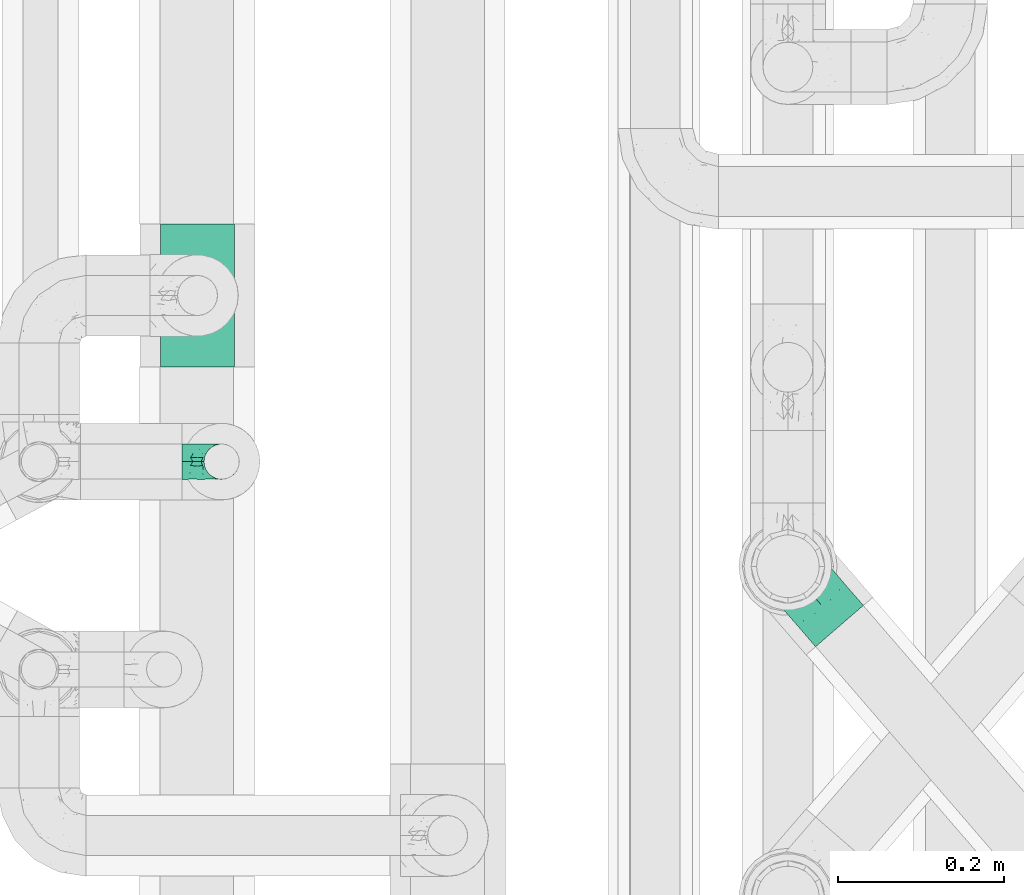
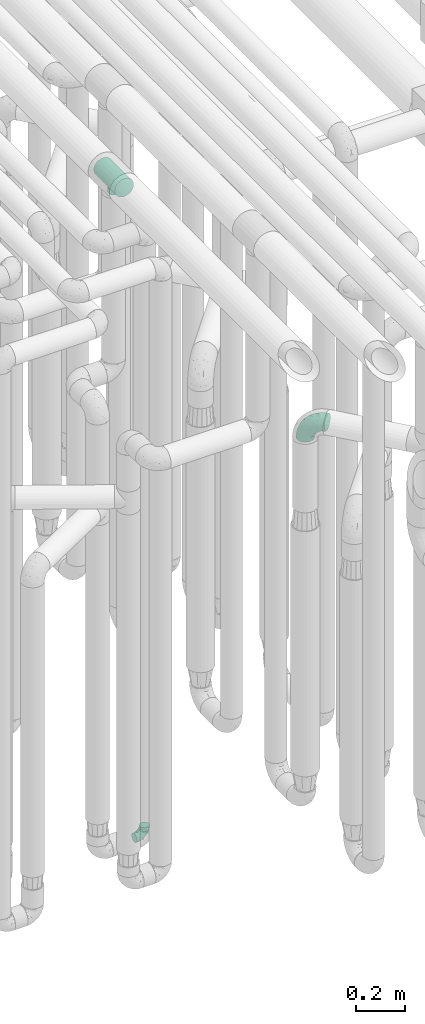
# One storey, part 611 of 827: 3 flow fittings.
"""IFC2X3 building model written with IfcOpenShell, lengths in millimetres."""

from ifc_helpers import new_model, entity, si_unit, converted_unit, derived_unit, direction, frame, origin, place, context, subcontext, project, spatial, faceted_brep, source, transform, mapped, material, type_object, type_shapes, element, save


model = new_model("IFC2X3")

# Units and contexts
model_context = context("Model", 3, precision=0.01, world=origin(), true_north=direction((6.12303176911189e-17, 1.0)))
body_context = subcontext(model_context, "Body", "Model", "MODEL_VIEW")
ifc_project = project(units=[si_unit("LENGTHUNIT", "METRE", prefix="MILLI"), si_unit("AREAUNIT", "SQUARE_METRE"), si_unit("VOLUMEUNIT", "CUBIC_METRE"), converted_unit("PLANEANGLEUNIT", "DEGREE", entity("IfcRatioMeasure", 0.0174532925199433), si_unit("PLANEANGLEUNIT", "RADIAN"), dimensions=[0, 0, 0, 0, 0, 0, 0]), si_unit("MASSUNIT", "GRAM", prefix="KILO"), derived_unit("MASSDENSITYUNIT", [(si_unit("MASSUNIT", "GRAM", prefix="KILO"), 1), (si_unit("LENGTHUNIT", "METRE"), -3)]), derived_unit("MOMENTOFINERTIAUNIT", [(si_unit("LENGTHUNIT", "METRE"), 4)]), si_unit("TIMEUNIT", "SECOND"), si_unit("FREQUENCYUNIT", "HERTZ"), si_unit("THERMODYNAMICTEMPERATUREUNIT", "DEGREE_CELSIUS"), derived_unit("THERMALTRANSMITTANCEUNIT", [(si_unit("MASSUNIT", "GRAM", prefix="KILO"), 1), (si_unit("THERMODYNAMICTEMPERATUREUNIT", "KELVIN"), -1), (si_unit("TIMEUNIT", "SECOND"), -3)]), derived_unit("VOLUMETRICFLOWRATEUNIT", [(si_unit("LENGTHUNIT", "METRE"), 3), (si_unit("TIMEUNIT", "SECOND"), -1)]), derived_unit("MASSFLOWRATEUNIT", [(si_unit("MASSUNIT", "GRAM", prefix="KILO"), 1), (si_unit("TIMEUNIT", "SECOND"), -1)]), derived_unit("ROTATIONALFREQUENCYUNIT", [(si_unit("TIMEUNIT", "SECOND"), -1)]), si_unit("ELECTRICCURRENTUNIT", "AMPERE"), si_unit("ELECTRICVOLTAGEUNIT", "VOLT"), si_unit("POWERUNIT", "WATT"), si_unit("FORCEUNIT", "NEWTON", prefix="KILO"), si_unit("ILLUMINANCEUNIT", "LUX"), si_unit("LUMINOUSFLUXUNIT", "LUMEN"), si_unit("LUMINOUSINTENSITYUNIT", "CANDELA"), derived_unit("USERDEFINED", [(si_unit("MASSUNIT", "GRAM", prefix="KILO"), -1), (si_unit("LENGTHUNIT", "METRE"), -2), (si_unit("TIMEUNIT", "SECOND"), 3), (si_unit("LUMINOUSFLUXUNIT", "LUMEN"), 1)]), derived_unit("LINEARVELOCITYUNIT", [(si_unit("LENGTHUNIT", "METRE"), 1), (si_unit("TIMEUNIT", "SECOND"), -1)]), si_unit("PRESSUREUNIT", "PASCAL"), derived_unit("USERDEFINED", [(si_unit("LENGTHUNIT", "METRE"), -2), (si_unit("MASSUNIT", "GRAM", prefix="KILO"), 1), (si_unit("TIMEUNIT", "SECOND"), -2)]), derived_unit("LINEARFORCEUNIT", [(si_unit("MASSUNIT", "GRAM", prefix="KILO"), 1), (si_unit("LENGTHUNIT", "METRE"), 1), (si_unit("TIMEUNIT", "SECOND"), -2), (si_unit("LENGTHUNIT", "METRE"), -1)]), derived_unit("PLANARFORCEUNIT", [(si_unit("MASSUNIT", "GRAM", prefix="KILO"), 1), (si_unit("LENGTHUNIT", "METRE"), 1), (si_unit("TIMEUNIT", "SECOND"), -2), (si_unit("LENGTHUNIT", "METRE"), -2)])], contexts=[model_context])

# Site, building, storey
site_placement = place(None, origin())
site = spatial("IfcSite", under=ifc_project, at=site_placement, CompositionType="ELEMENT")
building_placement = place(site_placement, origin())
building = spatial("IfcBuilding", under=site, at=building_placement, CompositionType="ELEMENT")
storey_placement = place(building_placement, frame((0.0, 0.0, 28200.0)))
storey = spatial("IfcBuildingStorey", under=building, at=storey_placement, Name="08", CompositionType="ELEMENT", Elevation=28200.0)

# Flow fittings
ifc_material = material()
pipe_fitting_type_1 = type_object("IfcPipeFittingType", Name="ADSK_1", PredefinedType="NOTDEFINED", material=ifc_material)
shared_shape_1 = source(origin(), body_context, "Body", "Brep", [
    faceted_brep([(-48.0, 10.6, -18.36), (-48.0, 5.49, -20.48), (-48.0, 0.0, -21.2), (-48.0, -5.49, -20.48), (-48.0, -10.6, -18.36), (-48.0, -14.99, -14.99), (-48.0, -18.36, -10.6), (-48.0, -20.48, -5.49), (-48.0, -21.2, 0.0), (-48.0, -20.48, 5.49), (-48.0, -18.36, 10.6), (-48.0, -14.99, 14.99), (-48.0, -10.6, 18.36), (-48.0, -5.49, 20.48), (-48.0, 0.0, 21.2), (-48.0, 5.49, 20.48), (-48.0, 10.6, 18.36), (-48.0, 14.99, 14.99), (-48.0, 18.36, 10.6), (-48.0, 20.48, 5.49), (-48.0, 21.2, 0.0), (-48.0, 20.48, -5.49), (-48.0, 18.36, -10.6), (-48.0, 14.99, -14.99), (0.0, 48.0, -21.2), (-5.49, 48.0, -20.48), (-10.6, 48.0, -18.36), (-14.99, 48.0, -14.99), (-18.36, 48.0, -10.6), (-20.48, 48.0, -5.49), (-21.2, 48.0, 0.0), (-20.48, 48.0, 5.49), (-18.36, 48.0, 10.6), (-14.99, 48.0, 14.99), (-10.6, 48.0, 18.36), (-5.49, 48.0, 20.48), (0.0, 48.0, 21.2), (5.49, 48.0, 20.48), (10.6, 48.0, 18.36), (14.99, 48.0, 14.99), (18.36, 48.0, 10.6), (20.48, 48.0, 5.49), (21.2, 48.0, 0.0), (20.48, 48.0, -5.49), (18.36, 48.0, -10.6), (14.99, 48.0, -14.99), (10.6, 48.0, -18.36), (5.49, 48.0, -20.48), (-35.25, -16.22, 12.01), (-34.76, -18.57, 0.0), (-20.87, -12.37, 10.9), (-31.49, -11.78, 15.9), (-37.0, -2.58, 20.86), (-33.89, 3.62, 21.15), (-31.81, -18.14, 6.76), (-5.78, 5.78, 17.67), (-19.42, -4.1, 17.86), (-9.6, -3.39, 13.73), (-35.44, -7.73, 19.13), (11.78, 31.49, 15.9), (-5.93, -5.46, 6.95), (-18.45, -13.78, 5.46), (-10.29, -8.43, 0.0), (-24.6, 0.55, 20.62), (-37.28, 17.94, 13.81), (-33.38, 22.85, 9.59), (-41.46, 20.06, 8.75), (-29.51, 20.45, 15.16), (-15.04, 10.79, 21.13), (-7.08, 16.98, 20.93), (-8.39, 23.51, 21.15), (-40.86, 13.03, 17.26), (-8.05, 41.26, 19.83), (-3.21, 35.97, 21.14), (8.53, 19.66, 14.74), (4.1, 19.42, 17.86), (-37.72, 22.66, 4.78), (-37.07, 8.58, 19.98), (-13.0, 5.43, 19.97), (-3.78, 13.93, 19.7), (3.02, 8.69, 13.43), (-2.27, -0.05, 10.65), (6.22, 6.99, 7.09), (-22.25, 34.6, 9.45), (18.14, 31.81, 6.76), (16.22, 35.25, 12.01), (12.37, 20.87, 10.9), (7.73, 35.44, 19.13), (-21.52, -15.93, 0.0), (2.58, 37.0, 20.86), (18.57, 34.76, 0.0), (13.78, 18.45, 5.46), (15.93, 21.52, 0.0), (-20.03, -8.54, 14.9), (-28.6, 28.6, 5.16), (-24.79, 34.6, 0.0), (-34.6, 24.79, 0.0), (-22.81, 37.41, 4.68), (-23.36, 26.33, 14.79), (-13.68, 37.05, 17.49), (-17.72, 38.12, 13.73), (-26.25, 27.3, 11.24), (-9.71, 32.34, 20.14), (-17.26, 25.6, 18.71), (-26.33, 9.99, 20.77), (-24.06, 6.05, 21.2), (-25.02, 15.46, 19.56), (-24.3, 20.72, 17.57), (-31.95, 15.23, 17.8), (-13.53, 24.7, 20.21), (-17.6, 17.6, 20.6), (-0.55, 24.6, 20.62), (-11.41, -7.48, 10.43), (0.93, -0.93, 0.0), (8.43, 10.29, 0.0), (-11.41, -7.48, -10.43), (-20.1, -8.84, -14.66), (-9.6, -3.39, -13.73), (7.73, 35.44, -19.13), (4.1, 19.42, -17.86), (-0.55, 24.6, -20.62), (-38.12, 17.72, -13.73), (-37.05, 13.68, -17.49), (-32.34, 9.71, -20.14), (-41.26, 8.05, -19.83), (-37.41, 22.81, -4.68), (-23.51, 8.39, -21.15), (-35.97, 3.21, -21.14), (-28.6, 28.6, -5.16), (-31.81, -18.14, -6.76), (-18.45, -13.78, -5.46), (-25.6, 17.26, -18.71), (-19.42, -4.1, -17.86), (-17.94, 37.28, -13.81), (-22.85, 33.38, -9.59), (-20.06, 41.46, -8.75), (-31.49, -11.78, -15.9), (-35.25, -16.22, -12.01), (8.53, 19.66, -14.74), (11.78, 31.49, -15.9), (-9.99, 26.33, -20.77), (-6.05, 24.06, -21.2), (-10.79, 15.04, -21.13), (-37.0, -2.58, -20.86), (-16.98, 7.08, -20.93), (-5.43, 13.0, -19.97), (-13.93, 3.78, -19.7), (-20.87, -12.37, -10.9), (-26.33, 23.36, -14.79), (-22.66, 37.72, -4.78), (13.78, 18.45, -5.46), (18.14, 31.81, -6.76), (-15.46, 25.02, -19.56), (-20.72, 24.3, -17.57), (16.22, 35.25, -12.01), (-13.03, 40.86, -17.26), (-8.58, 37.07, -19.98), (2.58, 37.0, -20.86), (-3.62, 33.89, -21.15), (-34.6, 22.25, -9.45), (6.22, 6.99, -7.09), (-20.45, 29.51, -15.16), (-35.44, -7.73, -19.13), (12.37, 20.87, -10.9), (-27.3, 26.25, -11.24), (-15.23, 31.95, -17.8), (-24.7, 13.53, -20.21), (-24.6, 0.55, -20.62), (-5.78, 5.78, -17.67), (-17.6, 17.6, -20.6), (3.02, 8.69, -13.43), (-5.93, -5.46, -6.95), (-2.27, -0.05, -10.65)], [[[0, 1, 2, 3, 4, 5, 6, 7, 8, 9, 10, 11, 12, 13, 14, 15, 16, 17, 18, 19, 20, 21, 22, 23]], [[24, 25, 26, 27, 28, 29, 30, 31, 32, 33, 34, 35, 36, 37, 38, 39, 40, 41, 42, 43, 44, 45, 46, 47]], [[10, 48, 11]], [[9, 8, 49]], [[48, 50, 51]], [[14, 52, 53]], [[10, 54, 48]], [[9, 54, 10]], [[55, 56, 57]], [[51, 12, 11]], [[51, 58, 12]], [[59, 39, 38]], [[60, 61, 62]], [[58, 56, 63]], [[64, 65, 66]], [[67, 65, 64]], [[68, 69, 70]], [[16, 71, 17]], [[13, 52, 14]], [[35, 72, 73]], [[14, 53, 15]], [[17, 64, 18]], [[74, 59, 75]], [[20, 19, 76]], [[66, 19, 18]], [[77, 15, 53]], [[15, 77, 16]], [[69, 78, 79]], [[80, 81, 82]], [[32, 31, 83]], [[84, 85, 86]], [[59, 87, 75]], [[61, 54, 88]], [[36, 89, 37]], [[84, 41, 40]], [[36, 35, 73]], [[90, 41, 84]], [[40, 39, 85]], [[12, 58, 13]], [[85, 84, 40]], [[91, 84, 86]], [[84, 92, 90]], [[87, 38, 37]], [[93, 56, 51]], [[65, 94, 76]], [[94, 95, 96]], [[84, 91, 92]], [[95, 97, 30]], [[98, 99, 100]], [[76, 94, 96]], [[101, 98, 83]], [[100, 99, 33]], [[102, 70, 73]], [[103, 102, 99]], [[94, 97, 95]], [[72, 99, 102]], [[72, 35, 34]], [[34, 33, 99]], [[9, 49, 54]], [[87, 59, 38]], [[104, 105, 68]], [[106, 103, 107]], [[106, 77, 104]], [[71, 64, 17]], [[108, 107, 67]], [[33, 32, 100]], [[109, 103, 110]], [[102, 109, 70]], [[89, 73, 111]], [[50, 48, 54]], [[51, 11, 48]], [[56, 58, 51]], [[88, 54, 49]], [[52, 58, 63]], [[50, 112, 93]], [[56, 55, 78]], [[39, 59, 85]], [[86, 85, 59]], [[89, 87, 37]], [[42, 41, 90]], [[111, 79, 75]], [[111, 75, 87]], [[75, 55, 80]], [[104, 77, 53]], [[71, 77, 108]], [[32, 83, 100]], [[98, 100, 83]], [[99, 98, 103]], [[106, 107, 108]], [[68, 70, 110]], [[111, 73, 70]], [[68, 110, 104]], [[68, 63, 78]], [[57, 93, 112]], [[80, 55, 57]], [[61, 50, 54]], [[80, 82, 86]], [[81, 57, 112]], [[74, 86, 59]], [[60, 113, 82]], [[82, 114, 91]], [[101, 94, 65]], [[97, 94, 83]], [[73, 89, 36]], [[87, 89, 111]], [[58, 52, 13]], [[53, 52, 63]], [[104, 53, 105]], [[106, 104, 110]], [[20, 76, 96]], [[76, 19, 66]], [[103, 106, 110]], [[77, 106, 108]], [[103, 98, 107]], [[67, 107, 98]], [[67, 98, 101]], [[108, 67, 64]], [[53, 63, 105]], [[63, 68, 105]], [[83, 31, 97]], [[30, 97, 31]], [[62, 113, 60]], [[112, 61, 60]], [[61, 88, 62]], [[86, 82, 91]], [[56, 78, 63]], [[114, 82, 113]], [[114, 92, 91]], [[79, 78, 55]], [[75, 79, 55]], [[69, 79, 111]], [[70, 69, 111]], [[78, 69, 68]], [[77, 71, 16]], [[64, 71, 108]], [[64, 66, 18]], [[76, 66, 65]], [[99, 72, 34]], [[73, 72, 102]], [[94, 101, 83]], [[67, 101, 65]], [[75, 80, 74]], [[80, 86, 74]], [[70, 109, 110]], [[102, 103, 109]], [[50, 93, 51]], [[57, 56, 93]], [[61, 112, 50]], [[81, 112, 60]], [[82, 81, 60]], [[80, 57, 81]], [[115, 116, 117]], [[118, 119, 120]], [[121, 122, 23]], [[123, 124, 122]], [[96, 125, 20]], [[123, 126, 127]], [[128, 96, 95]], [[129, 130, 88]], [[123, 122, 131]], [[116, 132, 117]], [[133, 134, 135]], [[0, 124, 1]], [[5, 136, 137]], [[138, 119, 139]], [[129, 88, 49]], [[140, 141, 142]], [[6, 5, 137]], [[46, 118, 47]], [[143, 3, 2]], [[144, 145, 146]], [[6, 129, 7]], [[129, 137, 147]], [[127, 2, 1]], [[148, 122, 121]], [[128, 125, 96]], [[134, 128, 149]], [[95, 149, 128]], [[150, 151, 92]], [[30, 29, 149]], [[152, 131, 153]], [[27, 133, 28]], [[154, 45, 44]], [[136, 5, 4]], [[27, 26, 155]], [[156, 26, 25]], [[24, 157, 158]], [[24, 47, 157]], [[22, 21, 159]], [[160, 150, 114]], [[134, 133, 161]], [[142, 144, 126]], [[46, 139, 118]], [[162, 136, 4]], [[156, 25, 158]], [[1, 124, 127]], [[115, 147, 116]], [[45, 154, 139]], [[139, 46, 45]], [[154, 163, 139]], [[162, 4, 3]], [[42, 90, 43]], [[130, 129, 147]], [[49, 7, 129]], [[43, 151, 44]], [[0, 23, 122]], [[24, 158, 25]], [[136, 162, 132]], [[135, 29, 28]], [[43, 90, 151]], [[164, 148, 159]], [[152, 156, 140]], [[155, 133, 27]], [[165, 153, 161]], [[23, 22, 121]], [[123, 131, 166]], [[123, 166, 126]], [[143, 127, 167]], [[147, 137, 136]], [[8, 7, 49]], [[129, 6, 137]], [[143, 162, 3]], [[167, 146, 132]], [[167, 132, 162]], [[132, 168, 117]], [[44, 151, 154]], [[92, 151, 90]], [[163, 154, 151]], [[119, 118, 139]], [[157, 118, 120]], [[138, 139, 163]], [[119, 168, 145]], [[140, 156, 158]], [[155, 156, 165]], [[22, 159, 121]], [[148, 121, 159]], [[122, 148, 131]], [[152, 153, 165]], [[142, 126, 169]], [[167, 127, 126]], [[142, 169, 140]], [[142, 120, 145]], [[168, 170, 117]], [[160, 171, 172]], [[115, 172, 171]], [[171, 62, 130]], [[119, 170, 168]], [[170, 163, 160]], [[150, 163, 151]], [[113, 171, 160]], [[164, 128, 134]], [[125, 128, 159]], [[127, 143, 2]], [[162, 143, 167]], [[118, 157, 47]], [[158, 157, 120]], [[140, 158, 141]], [[152, 140, 169]], [[30, 149, 95]], [[149, 29, 135]], [[131, 152, 169]], [[156, 152, 165]], [[131, 148, 153]], [[161, 153, 148]], [[161, 148, 164]], [[165, 161, 133]], [[158, 120, 141]], [[120, 142, 141]], [[159, 21, 125]], [[20, 125, 21]], [[115, 130, 147]], [[114, 113, 160]], [[62, 171, 113]], [[62, 88, 130]], [[160, 163, 150]], [[150, 92, 114]], [[119, 145, 120]], [[146, 145, 168]], [[132, 146, 168]], [[144, 146, 167]], [[126, 144, 167]], [[145, 144, 142]], [[156, 155, 26]], [[133, 155, 165]], [[133, 135, 28]], [[149, 135, 134]], [[122, 124, 0]], [[127, 124, 123]], [[128, 164, 159]], [[161, 164, 134]], [[163, 170, 138]], [[170, 119, 138]], [[131, 169, 166]], [[126, 166, 169]], [[147, 136, 116]], [[132, 116, 136]], [[172, 115, 117]], [[130, 115, 171]], [[117, 170, 172]], [[160, 172, 170]]]),
])
type_shapes(pipe_fitting_type_1, [shared_shape_1])
flow_fitting_1_placement = place(storey_placement, frame((35948.05, 10606.2, 400.0), z_axis=(0.0, -1.0, 0.0), x_axis=(1.0, 0.0, 0.0)))
element("IfcFlowFitting", 1, at=flow_fitting_1_placement, inside=storey, type_object=pipe_fitting_type_1, material=ifc_material, Name="ADSK_1", ObjectType="ADSK_1", context=body_context, shape_type="MappedRepresentation", body=[
    mapped(shared_shape_1, transform((0.0, 0.0, 0.0), scale=1.0)),
])
pipe_fitting_type_2 = type_object("IfcPipeFittingType", Name="ADSK_1", PredefinedType="NOTDEFINED", material=ifc_material)
shared_shape_2 = source(origin(), body_context, "Body", "Brep", [
    faceted_brep([(-95.0, 19.02, -32.95), (-95.0, 9.85, -36.75), (-95.0, 0.0, -38.05), (-95.0, -9.85, -36.75), (-95.0, -19.03, -32.95), (-95.0, -26.91, -26.91), (-95.0, -32.95, -19.03), (-95.0, -36.75, -9.85), (-95.0, -38.05, 0.0), (-95.0, -36.75, 9.85), (-95.0, -32.95, 19.02), (-95.0, -26.91, 26.91), (-95.0, -19.03, 32.95), (-95.0, -9.85, 36.75), (-95.0, 0.0, 38.05), (-95.0, 9.85, 36.75), (-95.0, 19.02, 32.95), (-95.0, 26.91, 26.91), (-95.0, 32.95, 19.02), (-95.0, 36.75, 9.85), (-95.0, 38.05, 0.0), (-95.0, 36.75, -9.85), (-95.0, 32.95, -19.03), (-95.0, 26.91, -26.91), (0.0, 95.0, -38.05), (-9.85, 95.0, -36.75), (-19.02, 95.0, -32.95), (-26.91, 95.0, -26.91), (-32.95, 95.0, -19.03), (-36.75, 95.0, -9.85), (-38.05, 95.0, 0.0), (-36.75, 95.0, 9.85), (-32.95, 95.0, 19.02), (-26.91, 95.0, 26.91), (-19.02, 95.0, 32.95), (-9.85, 95.0, 36.75), (0.0, 95.0, 38.05), (9.85, 95.0, 36.75), (19.03, 95.0, 32.95), (26.91, 95.0, 26.91), (32.95, 95.0, 19.02), (36.75, 95.0, 9.85), (38.05, 95.0, 0.0), (36.75, 95.0, -9.85), (32.95, 95.0, -19.03), (26.91, 95.0, -26.91), (19.03, 95.0, -32.95), (9.85, 95.0, -36.75), (-7.99, -4.96, 6.3), (-0.92, 0.92, 0.0), (4.62, 8.1, 8.01), (-76.19, -35.57, 0.0), (-64.32, -32.32, 12.43), (20.51, 62.45, 28.68), (-60.56, -33.52, 0.0), (-70.4, -13.47, 34.42), (-39.61, -5.88, 32.32), (-49.6, 2.07, 37.1), (-70.34, -28.81, 21.71), (14.64, 40.81, 26.5), (5.88, 39.61, 32.32), (3.59, 20.77, 25.31), (-40.45, 68.06, 16.75), (-62.45, -20.51, 28.68), (-44.52, -26.87, 0.0), (-28.47, -20.22, 0.0), (-26.43, -17.83, 8.75), (-76.1, 39.63, 10.76), (-72.74, 37.58, 18.19), (-60.35, 46.18, 14.61), (-13.4, 13.4, 32.12), (-20.77, -3.59, 25.31), (-14.66, 81.47, 35.56), (-6.22, 71.26, 37.92), (-57.5, 42.48, 22.79), (-15.0, 34.74, 37.7), (-27.1, 12.08, 36.05), (-9.2, 28.81, 35.63), (-79.98, 23.7, 30.95), (-73.68, -4.3, 37.48), (-30.74, 21.67, 37.97), (-62.36, 47.59, 6.79), (-72.71, 32.83, 24.69), (-67.42, 7.02, 37.95), (-32.13, 75.27, 24.51), (-43.46, 51.47, 26.26), (-24.98, 73.15, 31.29), (20.59, 41.28, 19.85), (7.79, 16.09, 15.86), (-73.21, 42.39, 0.0), (-54.73, 54.73, 0.0), (-73.44, 15.79, 35.79), (-5.94, 4.32, 20.43), (28.81, 70.34, 21.71), (32.32, 64.32, 12.43), (-53.59, 26.2, 35.09), (-52.02, 19.31, 37.21), (21.38, 33.53, 10.34), (26.87, 44.52, 0.0), (-48.28, 12.14, 38.05), (4.3, 73.68, 37.48), (-44.08, -25.52, 12.79), (-41.28, -20.59, 19.85), (35.57, 76.19, 0.0), (-47.26, 54.3, 20.18), (-47.4, 61.99, 8.58), (-42.39, 73.21, 0.0), (-39.67, 78.86, 7.21), (-45.69, 36.84, 33.11), (-32.83, 50.13, 33.35), (13.47, 70.4, 34.42), (-18.25, 63.73, 36.07), (-40.63, -13.75, 27.22), (-16.63, 46.37, 37.95), (-53.47, 38.79, 28.59), (-26.07, 48.54, 36.15), (-34.51, 34.51, 36.86), (-2.07, 49.6, 37.1), (-22.79, -10.49, 19.23), (-61.73, 28.67, 31.87), (9.65, 14.7, 0.0), (20.22, 28.47, 0.0), (33.52, 60.56, 0.0), (-11.42, -5.44, 13.25), (-14.7, -9.65, 0.0), (-81.47, 14.66, -35.56), (-62.45, -20.51, -28.68), (-71.26, 6.22, -37.92), (-75.27, 32.13, -24.51), (-73.15, 24.98, -31.29), (13.47, 70.4, -34.42), (5.88, 39.61, -32.32), (-2.07, 49.6, -37.1), (-78.86, 39.67, -7.21), (-70.4, -13.47, -34.42), (-39.61, -5.88, -32.32), (-61.99, 47.4, -8.58), (32.32, 64.32, -12.43), (28.81, 70.34, -21.71), (-63.73, 18.25, -36.07), (-50.13, 32.83, -33.35), (4.3, 73.68, -37.48), (-7.02, 67.42, -37.95), (-39.63, 76.1, -10.76), (-46.18, 60.35, -14.61), (-47.59, 62.36, -6.79), (-64.32, -32.32, -12.43), (-26.2, 53.59, -35.09), (-15.79, 73.44, -35.79), (-19.31, 52.02, -37.21), (-37.58, 72.74, -18.19), (-70.34, -28.81, -21.71), (-42.48, 57.5, -22.79), (-38.79, 53.47, -28.59), (-51.47, 43.46, -26.26), (-32.83, 72.71, -24.69), (-46.37, 16.63, -37.95), (-73.68, -4.3, -37.48), (-41.28, -20.59, -19.85), (-44.08, -25.52, -12.79), (13.75, 40.63, -27.22), (20.51, 62.45, -28.68), (-68.06, 40.45, -16.75), (-54.3, 47.26, -20.18), (-12.14, 48.28, -38.05), (-21.67, 30.74, -37.97), (-36.84, 45.69, -33.11), (-11.42, -5.44, -13.25), (7.79, 16.09, -15.86), (4.62, 8.1, -8.01), (-23.7, 79.98, -30.95), (-26.43, -17.83, -8.75), (-7.99, -4.96, -6.3), (-40.81, -14.64, -26.5), (-20.77, -3.59, -25.31), (-34.74, 15.0, -37.7), (-12.08, 27.1, -36.05), (-28.81, 9.2, -35.63), (-22.79, -10.49, -19.23), (21.38, 33.53, -10.34), (20.59, 41.28, -19.85), (-48.54, 26.07, -36.15), (-49.6, 2.07, -37.1), (-13.4, 13.4, -32.12), (3.59, 20.77, -25.31), (-28.67, 61.73, -31.87), (-34.51, 34.51, -36.86), (-5.94, 4.32, -20.43)], [[[0, 1, 2, 3, 4, 5, 6, 7, 8, 9, 10, 11, 12, 13, 14, 15, 16, 17, 18, 19, 20, 21, 22, 23]], [[24, 25, 26, 27, 28, 29, 30, 31, 32, 33, 34, 35, 36, 37, 38, 39, 40, 41, 42, 43, 44, 45, 46, 47]], [[48, 49, 50]], [[51, 52, 9]], [[53, 39, 38]], [[9, 52, 10]], [[54, 52, 51]], [[55, 56, 57]], [[11, 10, 58]], [[59, 60, 61]], [[32, 31, 62]], [[63, 12, 11]], [[63, 55, 12]], [[64, 65, 66]], [[67, 68, 69]], [[70, 56, 71]], [[35, 72, 73]], [[69, 68, 74]], [[75, 76, 77]], [[16, 78, 17]], [[13, 79, 14]], [[76, 75, 80]], [[67, 69, 81]], [[18, 17, 82]], [[14, 79, 83]], [[20, 19, 67]], [[84, 85, 86]], [[87, 61, 88]], [[89, 81, 90]], [[18, 82, 68]], [[15, 91, 16]], [[14, 83, 15]], [[71, 92, 61]], [[17, 78, 82]], [[93, 87, 94]], [[95, 91, 96]], [[97, 98, 94]], [[86, 72, 34]], [[96, 99, 80]], [[37, 36, 100]], [[40, 39, 93]], [[40, 94, 41]], [[64, 66, 101]], [[93, 94, 40]], [[58, 102, 63]], [[94, 103, 41]], [[94, 87, 97]], [[104, 69, 74]], [[34, 33, 86]], [[105, 69, 104]], [[52, 58, 10]], [[106, 107, 30]], [[108, 109, 85]], [[105, 106, 90]], [[53, 110, 60]], [[86, 111, 72]], [[86, 109, 111]], [[33, 84, 86]], [[12, 55, 13]], [[112, 56, 63]], [[110, 38, 37]], [[34, 72, 35]], [[36, 35, 73]], [[111, 113, 73]], [[105, 107, 106]], [[110, 53, 38]], [[74, 114, 85]], [[91, 15, 83]], [[105, 90, 81]], [[107, 62, 31]], [[33, 32, 84]], [[115, 109, 116]], [[111, 115, 113]], [[100, 73, 117]], [[56, 55, 63]], [[79, 55, 57]], [[102, 118, 112]], [[56, 70, 76]], [[100, 110, 37]], [[117, 77, 60]], [[117, 60, 110]], [[60, 70, 61]], [[58, 52, 101]], [[63, 11, 58]], [[39, 53, 93]], [[87, 93, 53]], [[96, 91, 83]], [[78, 91, 119]], [[32, 62, 84]], [[84, 62, 104]], [[86, 85, 109]], [[85, 114, 108]], [[80, 113, 116]], [[117, 73, 113]], [[80, 116, 96]], [[80, 57, 76]], [[71, 112, 118]], [[61, 87, 59]], [[62, 107, 105]], [[97, 120, 121]], [[70, 71, 61]], [[71, 118, 92]], [[73, 100, 36]], [[110, 100, 117]], [[55, 79, 13]], [[83, 79, 57]], [[96, 83, 99]], [[116, 108, 95]], [[50, 97, 88]], [[97, 87, 88]], [[50, 49, 120]], [[122, 94, 98]], [[89, 20, 67]], [[105, 81, 69]], [[89, 67, 81]], [[68, 19, 18]], [[68, 67, 19]], [[74, 68, 82]], [[114, 82, 119]], [[74, 85, 104]], [[82, 114, 74]], [[114, 119, 108]], [[95, 108, 119]], [[116, 109, 108]], [[123, 48, 50]], [[97, 50, 120]], [[123, 50, 88]], [[91, 95, 119]], [[116, 95, 96]], [[84, 104, 85]], [[104, 62, 105]], [[83, 57, 99]], [[57, 80, 99]], [[66, 48, 123]], [[66, 124, 48]], [[118, 66, 123]], [[124, 66, 65]], [[66, 118, 101]], [[54, 64, 52]], [[124, 49, 48]], [[30, 107, 31]], [[91, 78, 16]], [[82, 78, 119]], [[56, 76, 57]], [[77, 76, 70]], [[60, 77, 70]], [[77, 117, 75]], [[117, 113, 75]], [[113, 80, 75]], [[9, 8, 51]], [[103, 94, 122]], [[103, 42, 41]], [[73, 72, 111]], [[113, 115, 116]], [[111, 109, 115]], [[102, 112, 63]], [[71, 56, 112]], [[118, 102, 101]], [[92, 123, 88]], [[123, 92, 118]], [[61, 92, 88]], [[87, 53, 59]], [[60, 59, 53]], [[97, 121, 98]], [[58, 101, 102]], [[64, 101, 52]], [[125, 1, 0]], [[126, 5, 4]], [[2, 1, 127]], [[1, 125, 127]], [[128, 129, 23]], [[130, 131, 132]], [[89, 133, 20]], [[126, 134, 135]], [[136, 89, 90]], [[137, 138, 44]], [[139, 129, 140]], [[24, 141, 142]], [[143, 144, 145]], [[125, 129, 139]], [[6, 146, 7]], [[147, 148, 149]], [[146, 51, 7]], [[143, 150, 144]], [[146, 6, 151]], [[152, 153, 154]], [[126, 4, 134]], [[0, 23, 129]], [[28, 155, 150]], [[43, 42, 103]], [[54, 146, 64]], [[139, 156, 127]], [[157, 3, 2]], [[151, 158, 159]], [[160, 131, 161]], [[22, 21, 162]], [[136, 144, 163]], [[149, 164, 165]], [[24, 142, 25]], [[166, 140, 154]], [[154, 129, 128]], [[143, 30, 29]], [[167, 168, 169]], [[155, 28, 27]], [[26, 170, 27]], [[171, 167, 172]], [[26, 25, 148]], [[27, 170, 155]], [[173, 135, 174]], [[144, 150, 152]], [[175, 176, 177]], [[24, 47, 141]], [[45, 161, 46]], [[148, 25, 142]], [[176, 175, 165]], [[64, 159, 171]], [[138, 45, 44]], [[130, 46, 161]], [[137, 44, 43]], [[178, 159, 158]], [[137, 103, 122]], [[163, 144, 152]], [[136, 133, 89]], [[103, 137, 43]], [[6, 5, 151]], [[178, 158, 173]], [[134, 4, 3]], [[178, 173, 174]], [[137, 98, 179]], [[145, 90, 106]], [[138, 180, 161]], [[46, 130, 47]], [[136, 90, 145]], [[133, 162, 21]], [[23, 22, 128]], [[139, 140, 181]], [[139, 181, 156]], [[157, 127, 182]], [[157, 134, 3]], [[182, 177, 135]], [[182, 135, 134]], [[135, 183, 174]], [[131, 130, 161]], [[141, 130, 132]], [[160, 180, 184]], [[131, 183, 176]], [[5, 126, 151]], [[158, 151, 126]], [[180, 138, 137]], [[161, 45, 138]], [[149, 148, 142]], [[170, 148, 185]], [[22, 162, 128]], [[128, 162, 163]], [[129, 154, 140]], [[154, 153, 166]], [[165, 156, 186]], [[182, 127, 156]], [[165, 186, 149]], [[165, 132, 176]], [[131, 184, 183]], [[187, 167, 178]], [[184, 168, 187]], [[167, 169, 172]], [[184, 180, 168]], [[174, 183, 184]], [[127, 157, 2]], [[134, 157, 182]], [[130, 141, 47]], [[142, 141, 132]], [[149, 142, 164]], [[186, 166, 147]], [[180, 179, 168]], [[169, 179, 120]], [[137, 179, 180]], [[179, 121, 120]], [[106, 30, 143]], [[136, 145, 144]], [[106, 143, 145]], [[150, 29, 28]], [[150, 143, 29]], [[152, 150, 155]], [[153, 155, 185]], [[152, 154, 163]], [[155, 153, 152]], [[153, 185, 166]], [[147, 166, 185]], [[186, 140, 166]], [[169, 120, 49]], [[169, 49, 172]], [[179, 169, 168]], [[148, 147, 185]], [[186, 147, 149]], [[128, 163, 154]], [[163, 162, 136]], [[142, 132, 164]], [[132, 165, 164]], [[171, 124, 65]], [[124, 171, 172]], [[64, 146, 159]], [[171, 159, 178]], [[171, 65, 64]], [[172, 49, 124]], [[162, 133, 136]], [[20, 133, 21]], [[148, 170, 26]], [[155, 170, 185]], [[131, 176, 132]], [[177, 176, 183]], [[135, 177, 183]], [[177, 182, 175]], [[182, 156, 175]], [[156, 165, 175]], [[51, 146, 54]], [[51, 8, 7]], [[129, 125, 0]], [[127, 125, 139]], [[140, 186, 181]], [[156, 181, 186]], [[158, 126, 173]], [[135, 173, 126]], [[187, 178, 174]], [[171, 178, 167]], [[184, 187, 174]], [[167, 187, 168]], [[180, 160, 161]], [[184, 131, 160]], [[98, 137, 122]], [[98, 121, 179]], [[151, 159, 146]]]),
])
type_shapes(pipe_fitting_type_2, [shared_shape_2])
flow_fitting_2_placement = place(storey_placement, frame((36629.64, 10480.2, 2305.0), z_axis=(0.756847522306242, 0.65359148401651, 0.0), x_axis=(0.0, 0.0, 1.0)))
element("IfcFlowFitting", 2, at=flow_fitting_2_placement, inside=storey, type_object=pipe_fitting_type_2, material=ifc_material, Name="ADSK_1", ObjectType="ADSK_1", context=body_context, shape_type="MappedRepresentation", body=[
    mapped(shared_shape_2, transform((0.0, 0.0, 0.0), scale=1.0)),
])
pipe_fitting_type_3 = type_object("IfcPipeFittingType", Name="ADSK_1", PredefinedType="NOTDEFINED", material=ifc_material)
shared_shape_3 = source(origin(), body_context, "Body", "Brep", [
    faceted_brep([(-86.0, 22.22, -38.49), (-86.0, 11.5, -42.94), (-86.0, 0.0, -44.45), (-86.0, -11.5, -42.94), (-86.0, -22.23, -38.49), (-86.0, -31.43, -31.43), (-86.0, -38.49, -22.23), (-86.0, -42.94, -11.5), (-86.0, -44.45, 0.0), (-86.0, -42.94, 11.5), (-86.0, -38.49, 22.22), (-86.0, -31.43, 31.43), (-86.0, -22.23, 38.49), (-86.0, -11.5, 42.94), (-86.0, 0.0, 44.45), (-86.0, 11.5, 42.94), (-86.0, 22.22, 38.49), (-86.0, 31.43, 31.43), (-86.0, 38.49, 22.22), (-86.0, 42.94, 11.5), (-86.0, 44.45, 0.0), (-86.0, 42.94, -11.5), (-86.0, 38.49, -22.23), (-86.0, 31.43, -31.43), (86.0, 0.0, -44.45), (86.0, 11.5, -42.94), (86.0, 22.22, -38.49), (86.0, 31.43, -31.43), (86.0, 38.49, -22.23), (86.0, 42.94, -11.5), (86.0, 44.45, 0.0), (86.0, 42.94, 11.5), (86.0, 38.49, 22.22), (86.0, 31.43, 31.43), (86.0, 22.22, 38.49), (86.0, 11.5, 42.94), (86.0, 0.0, 44.45), (86.0, -11.5, 42.94), (86.0, -22.23, 38.49), (86.0, -31.43, 31.43), (86.0, -38.49, 22.22), (86.0, -42.94, 11.5), (86.0, -44.45, 0.0), (86.0, -42.94, -11.5), (86.0, -38.49, -22.23), (86.0, -31.43, -31.43), (86.0, -22.23, -38.49), (86.0, -11.5, -42.94), (22.65, -43.65, 8.39), (23.4, -44.05, 4.19), (24.15, -44.45, 0.0), (18.45, -41.63, 15.58), (4.27, -37.56, 23.77), (12.15, -39.25, 20.87), (8.21, -38.4, 22.32), (-24.15, -44.45, 0.0), (-23.4, -44.05, 4.19), (-22.65, -43.65, 8.38), (-18.46, -41.63, 15.57), (-12.16, -39.25, 20.87), (-8.22, -38.4, 22.32), (-4.28, -37.56, 23.77), (0.0, -37.56, 23.77), (4.27, -37.56, -23.77), (12.15, -39.25, -20.87), (8.21, -38.4, -22.32), (18.45, -41.63, -15.58), (22.65, -43.65, -8.39), (23.4, -44.05, -4.19), (-4.28, -37.56, -23.77), (-8.22, -38.4, -22.32), (-12.16, -39.25, -20.87), (-18.46, -41.63, -15.57), (0.0, -37.56, -23.77), (-22.65, -43.65, -8.38), (-23.4, -44.05, -4.19), (0.0, -73.0, -24.15), (6.25, -73.0, -23.33), (12.08, -73.0, -20.91), (17.08, -73.0, -17.08), (20.91, -73.0, -12.08), (23.33, -73.0, -6.25), (24.15, -73.0, 0.0), (23.33, -73.0, 6.25), (20.91, -73.0, 12.07), (17.08, -73.0, 17.08), (12.08, -73.0, 20.91), (6.25, -73.0, 23.33), (0.0, -73.0, 24.15), (-6.25, -73.0, 23.33), (-12.07, -73.0, 20.91), (-17.08, -73.0, 17.08), (-20.91, -73.0, 12.07), (-23.33, -73.0, 6.25), (-24.15, -73.0, 0.0), (-23.33, -73.0, -6.25), (-20.91, -73.0, -12.08), (-17.08, -73.0, -17.08), (-12.07, -73.0, -20.91), (-6.25, -73.0, -23.33)], [[[0, 1, 2, 3, 4, 5, 6, 7, 8, 9, 10, 11, 12, 13, 14, 15, 16, 17, 18, 19, 20, 21, 22, 23]], [[24, 25, 26, 27, 28, 29, 30, 31, 32, 33, 34, 35, 36, 37, 38, 39, 40, 41, 42, 43, 44, 45, 46, 47]], [[42, 41, 48]], [[42, 48, 49, 50]], [[41, 51, 48]], [[40, 39, 52]], [[53, 51, 40]], [[40, 52, 54, 53]], [[39, 11, 52]], [[40, 51, 41]], [[8, 55, 56, 57]], [[9, 8, 57]], [[57, 58, 9]], [[10, 59, 60, 61]], [[59, 10, 58]], [[10, 61, 11]], [[58, 10, 9]], [[11, 61, 62, 52]], [[39, 38, 12, 11]], [[14, 13, 37, 36]], [[13, 12, 38, 37]], [[15, 14, 36, 35]], [[32, 31, 19, 18]], [[17, 16, 34, 33]], [[18, 17, 33, 32]], [[35, 34, 16, 15]], [[20, 19, 31, 30]], [[29, 28, 22, 21]], [[28, 27, 23, 22]], [[30, 29, 21, 20]], [[24, 47, 3, 2]], [[1, 0, 26, 25]], [[2, 1, 25, 24]], [[27, 26, 0, 23]], [[4, 3, 47, 46]], [[46, 45, 5, 4]], [[45, 44, 63]], [[44, 64, 65, 63]], [[44, 66, 64]], [[45, 63, 5]], [[43, 42, 67]], [[67, 66, 43]], [[42, 50, 68, 67]], [[43, 66, 44]], [[6, 69, 70, 71]], [[6, 5, 69]], [[71, 72, 6]], [[5, 63, 73, 69]], [[72, 74, 7]], [[74, 8, 7]], [[8, 74, 75, 55]], [[72, 7, 6]], [[76, 77, 78, 79, 80, 81, 82, 83, 84, 85, 86, 87, 88, 89, 90, 91, 92, 93, 94, 95, 96, 97, 98, 99]], [[93, 56, 94]], [[88, 61, 89]], [[60, 90, 89]], [[60, 59, 90]], [[86, 54, 87]], [[93, 57, 56]], [[49, 82, 50]], [[57, 93, 92]], [[56, 55, 94]], [[57, 92, 58]], [[90, 59, 91]], [[89, 61, 60]], [[91, 59, 58]], [[91, 58, 92]], [[88, 52, 62, 61]], [[86, 53, 54]], [[85, 53, 86]], [[48, 84, 83]], [[85, 84, 51]], [[52, 88, 87]], [[54, 52, 87]], [[53, 85, 51]], [[51, 84, 48]], [[82, 49, 83]], [[49, 48, 83]], [[81, 68, 82]], [[79, 66, 80]], [[65, 64, 78]], [[81, 67, 68]], [[80, 67, 81]], [[64, 79, 78]], [[68, 50, 82]], [[67, 80, 66]], [[77, 63, 65]], [[64, 66, 79]], [[76, 69, 73, 63]], [[98, 70, 99]], [[75, 94, 55]], [[98, 71, 70]], [[76, 63, 77]], [[75, 74, 95]], [[97, 71, 98]], [[74, 96, 95]], [[97, 96, 72]], [[69, 76, 99]], [[70, 69, 99]], [[71, 97, 72]], [[72, 96, 74]], [[94, 75, 95]], [[65, 78, 77]]]),
])
type_shapes(pipe_fitting_type_3, [shared_shape_3])
flow_fitting_3_placement = place(storey_placement, frame((35918.97, 10806.2, 3550.0), z_axis=(-1.0, 0.0, 0.0), x_axis=(0.0, -1.0, 9.11558916979079e-08)))
element("IfcFlowFitting", 3, at=flow_fitting_3_placement, inside=storey, type_object=pipe_fitting_type_3, material=ifc_material, Name="ADSK_1", ObjectType="ADSK_1", context=body_context, shape_type="MappedRepresentation", body=[
    mapped(shared_shape_3, transform((0.0, 0.0, 0.0), scale=1.0)),
])

save(model, "model.ifc")
